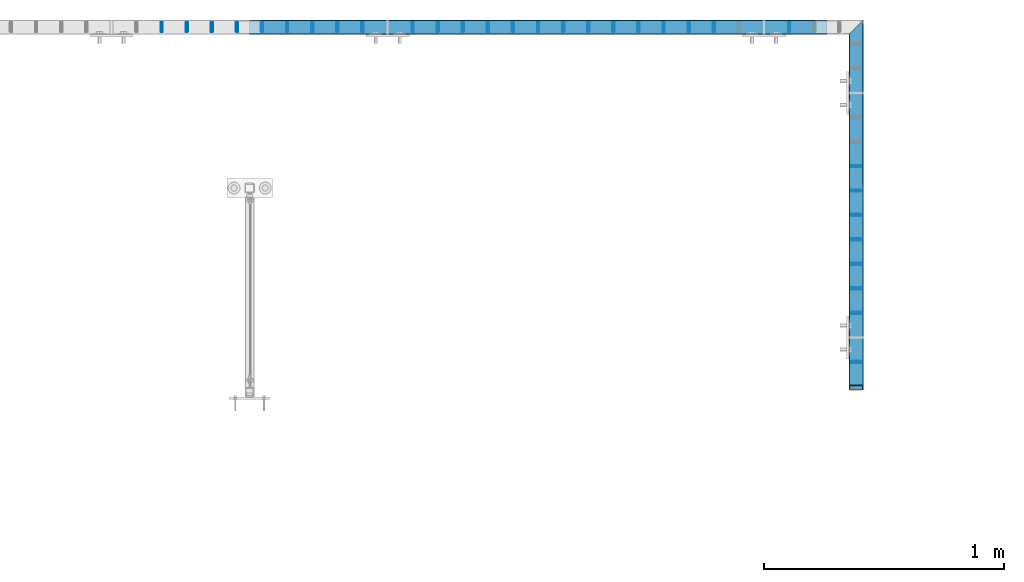
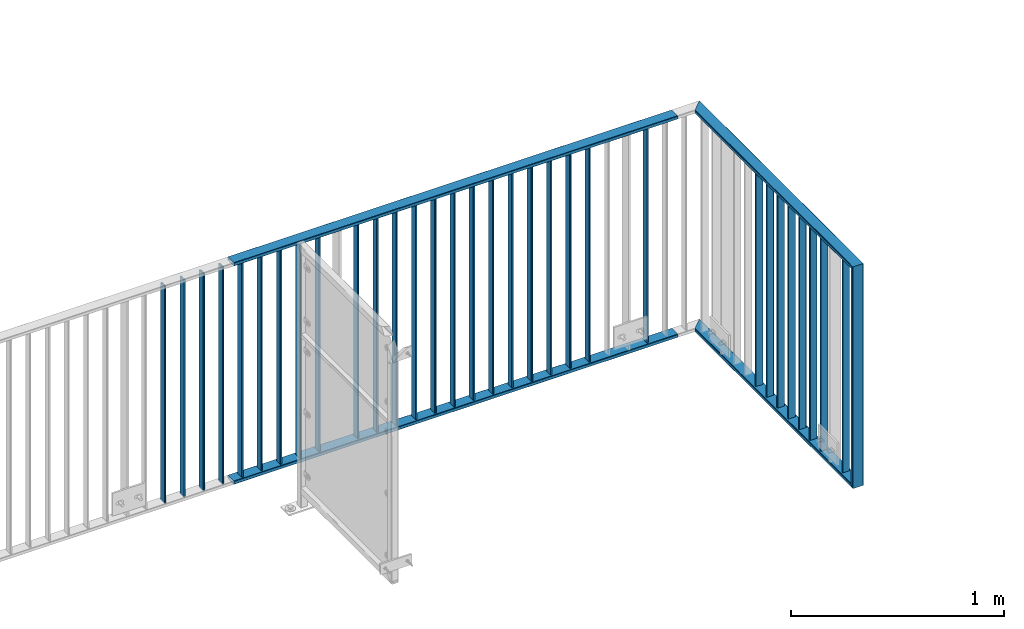
# One storey, part 12 of 156: 36 beams, 3 elements without a shape of their own.
"""IFC2X3 building model written with IfcOpenShell, lengths in millimetres."""

from ifc_helpers import new_model, si_unit, frame, origin_with_axes, origin_2d_with_axis, place, context, subcontext, project, spatial, hollow_rectangle, extrude, clip, halfspace, material, type_object, element, aggregate, save


model = new_model("IFC2X3")

# Units and contexts
model_context = context("Model", 3, precision=1e-05, world=origin_with_axes())
body_context = subcontext(model_context, "Body", "Model", "MODEL_VIEW")
ifc_project = project(units=[si_unit("LENGTHUNIT", "METRE", prefix="MILLI"), si_unit("AREAUNIT", "SQUARE_METRE"), si_unit("VOLUMEUNIT", "CUBIC_METRE"), si_unit("MASSUNIT", "GRAM", prefix="KILO"), si_unit("TIMEUNIT", "SECOND"), si_unit("PLANEANGLEUNIT", "RADIAN"), si_unit("SOLIDANGLEUNIT", "STERADIAN"), si_unit("THERMODYNAMICTEMPERATUREUNIT", "DEGREE_CELSIUS"), si_unit("LUMINOUSINTENSITYUNIT", "LUMEN")], contexts=[model_context])

# Site, building, storey
site_placement = place(None, origin_with_axes())
site = spatial("IfcSite", under=ifc_project, at=site_placement, CompositionType="ELEMENT")
building_placement = place(site_placement, origin_with_axes())
building = spatial("IfcBuilding", under=site, at=building_placement, Name="Undefined", CompositionType="ELEMENT")
storey_placement = place(building_placement, origin_with_axes())
storey = spatial("IfcBuildingStorey", under=building, at=storey_placement, Name="Undefined", CompositionType="ELEMENT", Elevation=0.0)

# Assembly, beams
assembly_1_placement = place(storey_placement, origin_with_axes())
assembly_1 = element("IfcElementAssembly", 1, at=assembly_1_placement, inside=storey, AssemblyPlace="NOTDEFINED", PredefinedType="RIGID_FRAME")
ifc_material = material(Name="STEEL/S235JR")
beam_type_1 = type_object("IfcBeamType", Name="K60/20/2", PredefinedType="NOTDEFINED")
beam_1_placement = place(assembly_1_placement, frame((17324.9994812012, 22558.0012658527, 4000.0), z_axis=(-1.0, 0.0, 0.0), x_axis=(0.0, 0.0, -1.0)))
beam_1 = element("IfcBeam", 2, at=beam_1_placement, type_object=beam_type_1, material=ifc_material, ObjectType="K60/20/2", context=body_context, shape_type="Clipping", body=[
    clip(clip(extrude(hollow_rectangle(XDim=20.0, YDim=60.0, WallThickness=2.0, InnerFilletRadius=2.0, OuterFilletRadius=4.0, at=origin_2d_with_axis()), frame((1280.2, 0.0, 0.0), z_axis=(-1.0, 0.0, 0.0), x_axis=(0.0, -1.0, 0.0)), (0.0, 0.0, 1.0), 1290.4), halfspace(frame((1270.0, 10.0, 0.0), z_axis=(0.707106781186548, -0.707106781186548, 0.0), x_axis=(0.0, 0.0, -1.0)), False)), halfspace(frame((20.0, -10.0, 0.0), z_axis=(-0.707106781186548, -0.707106781186548, 0.0), x_axis=(0.0, 0.0, -1.0)), False)),
])
beam_2_placement = place(assembly_1_placement, frame((17325.0016479492, 24031.4403835157, 2740.0), z_axis=(-1.0, 0.0, 0.0), x_axis=(0.0, -1.0, 0.0)))
beam_2 = element("IfcBeam", 3, at=beam_2_placement, type_object=beam_type_1, material=ifc_material, ObjectType="K60/20/2", context=body_context, shape_type="Clipping", body=[
    clip(clip(extrude(hollow_rectangle(XDim=20.0, YDim=60.0, WallThickness=2.0, InnerFilletRadius=2.0, OuterFilletRadius=4.0, at=origin_2d_with_axis()), frame((1513.83911766303, 0.0, 0.0), z_axis=(-1.0, 0.0, 0.0), x_axis=(0.0, -1.0, 0.0)), (0.0, 0.0, 1.0), 1580.79), halfspace(frame((1483.43911766303, -10.0, 0.002166748046875), z_axis=(-0.707106781186548, -0.707106781186548, 0.0), x_axis=(0.0, 0.0, -1.0)), True)), halfspace(frame((-56.5512297426903, 0.0, -30.0), z_axis=(-0.707106781186548, 0.0, 0.707106781186548), x_axis=(0.0, 1.0, 0.0)), False)),
])
beam_3_placement = place(assembly_1_placement, frame((17325.0016479492, 24031.4403835157, 3990.0), z_axis=(-1.0, 0.0, 0.0), x_axis=(0.0, -1.0, 0.0)))
beam_3 = element("IfcBeam", 4, at=beam_3_placement, type_object=beam_type_1, material=ifc_material, ObjectType="K60/20/2", context=body_context, shape_type="Clipping", body=[
    clip(clip(extrude(hollow_rectangle(XDim=20.0, YDim=60.0, WallThickness=2.0, InnerFilletRadius=2.0, OuterFilletRadius=4.0, at=origin_2d_with_axis()), frame((1513.83911766303, 0.0, 0.0), z_axis=(-1.0, 0.0, 0.0), x_axis=(0.0, -1.0, 0.0)), (0.0, 0.0, 1.0), 1580.79), halfspace(frame((1463.43911766303, -10.0, 0.002166748046875), z_axis=(-0.707106781186548, 0.707106781186548, 0.0), x_axis=(0.0, 0.0, -1.0)), True)), halfspace(frame((3.44877025730966, 0.0, 30.0), z_axis=(0.707106781186548, 0.0, -0.707106781186548), x_axis=(0.0, 1.0, 0.0)), True)),
])

assembly_2_placement = place(storey_placement, origin_with_axes())
assembly_2 = element("IfcElementAssembly", 5, at=assembly_2_placement, inside=storey, AssemblyPlace="NOTDEFINED", PredefinedType="RIGID_FRAME")
beam_4_placement = place(assembly_2_placement, frame((17202.6741455078, 24057.9916132584, 2740.0), z_axis=(0.0, -1.0, 0.0), x_axis=(-1.0, 0.0, 0.0)))
beam_4 = element("IfcBeam", 6, at=beam_4_placement, type_object=beam_type_1, material=ifc_material, ObjectType="K60/20/2", context=body_context, shape_type="SweptSolid", body=[
    extrude(hollow_rectangle(XDim=20.0, YDim=60.0, WallThickness=2.0, InnerFilletRadius=2.0, OuterFilletRadius=4.0, at=origin_2d_with_axis()), frame((2402.72054931641, 0.0, 0.0), z_axis=(-1.0, 0.0, 0.0), x_axis=(0.0, -1.0, 0.0)), (0.0, 0.0, 1.0), 2402.72),
])
beam_5_placement = place(assembly_2_placement, frame((17202.6741455078, 24057.9916132584, 3990.0), z_axis=(0.0, -1.0, 0.0), x_axis=(-1.0, 0.0, 0.0)))
beam_5 = element("IfcBeam", 7, at=beam_5_placement, type_object=beam_type_1, material=ifc_material, ObjectType="K60/20/2", context=body_context, shape_type="SweptSolid", body=[
    extrude(hollow_rectangle(XDim=20.0, YDim=60.0, WallThickness=2.0, InnerFilletRadius=2.0, OuterFilletRadius=4.0, at=origin_2d_with_axis()), frame((2402.72054931641, 0.0, 0.0), z_axis=(-1.0, 0.0, 0.0), x_axis=(0.0, -1.0, 0.0)), (0.0, 0.0, 1.0), 2402.72),
])

# Beam
beam_type_2 = type_object("IfcBeamType", Name="K40/10/1.5", PredefinedType="NOTDEFINED")
beam_6_placement = place(assembly_1_placement, frame((17325.0016402503, 22664.8503835168, 3980.00000000003), z_axis=(-1.0, 0.0, 0.0), x_axis=(0.0, 0.0, -1.0)))
beam_6 = element("IfcBeam", 8, at=beam_6_placement, type_object=beam_type_2, material=ifc_material, ObjectType="K40/10/1.5", context=body_context, shape_type="Clipping", body=[
    clip(clip(extrude(hollow_rectangle(XDim=10.0, YDim=40.0, WallThickness=1.5, InnerFilletRadius=1.5, OuterFilletRadius=3.0, at=origin_2d_with_axis()), frame((1237.00000000003, 0.0, 0.0), z_axis=(-1.0, 0.0, 0.0), x_axis=(0.0, -1.0, 0.0)), (0.0, 0.0, 1.0), 1244.0), halfspace(frame((1237.00000000003, 4.08341515816937, 47.1651964219418), z_axis=(1.0, 0.0, 0.0), x_axis=(0.0, -0.763991285051099, -0.645226562043109)), False)), halfspace(frame((-6.99999999997453, -4.08341515816574, 47.1651964219527), z_axis=(-1.0, 0.0, 0.0), x_axis=(0.0, 0.763991285051099, -0.645226562043109)), False)),
])

beam_7_placement = place(assembly_1_placement, frame((17325.0016402503, 22868.4103835168, 3980.00000000003), z_axis=(-1.0, 0.0, 0.0), x_axis=(0.0, 0.0, -1.0)))
beam_7 = element("IfcBeam", 9, at=beam_7_placement, type_object=beam_type_2, material=ifc_material, ObjectType="K40/10/1.5", context=body_context, shape_type="Clipping", body=[
    clip(clip(extrude(hollow_rectangle(XDim=10.0, YDim=40.0, WallThickness=1.5, InnerFilletRadius=1.5, OuterFilletRadius=3.0, at=origin_2d_with_axis()), frame((1237.00000000003, 0.0, 0.0), z_axis=(-1.0, 0.0, 0.0), x_axis=(0.0, -1.0, 0.0)), (0.0, 0.0, 1.0), 1244.0), halfspace(frame((1237.00000000003, 4.08341515816937, 47.1651964219418), z_axis=(1.0, 0.0, 0.0), x_axis=(0.0, -0.763991285051099, -0.645226562043109)), False)), halfspace(frame((-6.99999999997453, -4.08341515816574, 47.1651964219527), z_axis=(-1.0, 0.0, 0.0), x_axis=(0.0, 0.763991285051099, -0.645226562043109)), False)),
])

beam_8_placement = place(assembly_1_placement, frame((17325.0016402503, 22970.1903835168, 3980.00000000003), z_axis=(-1.0, 0.0, 0.0), x_axis=(0.0, 0.0, -1.0)))
beam_8 = element("IfcBeam", 10, at=beam_8_placement, type_object=beam_type_2, material=ifc_material, ObjectType="K40/10/1.5", context=body_context, shape_type="Clipping", body=[
    clip(clip(extrude(hollow_rectangle(XDim=10.0, YDim=40.0, WallThickness=1.5, InnerFilletRadius=1.5, OuterFilletRadius=3.0, at=origin_2d_with_axis()), frame((1237.00000000003, 0.0, 0.0), z_axis=(-1.0, 0.0, 0.0), x_axis=(0.0, -1.0, 0.0)), (0.0, 0.0, 1.0), 1244.0), halfspace(frame((1237.00000000003, 4.08341515816937, 47.1651964219418), z_axis=(1.0, 0.0, 0.0), x_axis=(0.0, -0.763991285051099, -0.645226562043109)), False)), halfspace(frame((-6.99999999997453, -4.08341515816574, 47.1651964219527), z_axis=(-1.0, 0.0, 0.0), x_axis=(0.0, 0.763991285051099, -0.645226562043109)), False)),
])

beam_9_placement = place(assembly_1_placement, frame((17325.0016402503, 23071.9703835168, 3980.00000000003), z_axis=(-1.0, 0.0, 0.0), x_axis=(0.0, 0.0, -1.0)))
beam_9 = element("IfcBeam", 11, at=beam_9_placement, type_object=beam_type_2, material=ifc_material, ObjectType="K40/10/1.5", context=body_context, shape_type="Clipping", body=[
    clip(clip(extrude(hollow_rectangle(XDim=10.0, YDim=40.0, WallThickness=1.5, InnerFilletRadius=1.5, OuterFilletRadius=3.0, at=origin_2d_with_axis()), frame((1237.00000000003, 0.0, 0.0), z_axis=(-1.0, 0.0, 0.0), x_axis=(0.0, -1.0, 0.0)), (0.0, 0.0, 1.0), 1244.0), halfspace(frame((1237.00000000003, 4.08341515816937, 47.1651964219418), z_axis=(1.0, 0.0, 0.0), x_axis=(0.0, -0.763991285051099, -0.645226562043109)), False)), halfspace(frame((-6.99999999997453, -4.08341515816574, 47.1651964219527), z_axis=(-1.0, 0.0, 0.0), x_axis=(0.0, 0.763991285051099, -0.645226562043109)), False)),
])

beam_10_placement = place(assembly_1_placement, frame((17325.0016402503, 23173.7503835168, 3980.00000000003), z_axis=(-1.0, 0.0, 0.0), x_axis=(0.0, 0.0, -1.0)))
beam_10 = element("IfcBeam", 12, at=beam_10_placement, type_object=beam_type_2, material=ifc_material, ObjectType="K40/10/1.5", context=body_context, shape_type="Clipping", body=[
    clip(clip(extrude(hollow_rectangle(XDim=10.0, YDim=40.0, WallThickness=1.5, InnerFilletRadius=1.5, OuterFilletRadius=3.0, at=origin_2d_with_axis()), frame((1237.00000000003, 0.0, 0.0), z_axis=(-1.0, 0.0, 0.0), x_axis=(0.0, -1.0, 0.0)), (0.0, 0.0, 1.0), 1244.0), halfspace(frame((1237.00000000003, 4.08341515816937, 47.1651964219418), z_axis=(1.0, 0.0, 0.0), x_axis=(0.0, -0.763991285051099, -0.645226562043109)), False)), halfspace(frame((-6.99999999997453, -4.08341515816574, 47.1651964219527), z_axis=(-1.0, 0.0, 0.0), x_axis=(0.0, 0.763991285051099, -0.645226562043109)), False)),
])

beam_11_placement = place(assembly_1_placement, frame((17325.0016402503, 23275.5303835168, 3980.00000000003), z_axis=(-1.0, 0.0, 0.0), x_axis=(0.0, 0.0, -1.0)))
beam_11 = element("IfcBeam", 13, at=beam_11_placement, type_object=beam_type_2, material=ifc_material, ObjectType="K40/10/1.5", context=body_context, shape_type="Clipping", body=[
    clip(clip(extrude(hollow_rectangle(XDim=10.0, YDim=40.0, WallThickness=1.5, InnerFilletRadius=1.5, OuterFilletRadius=3.0, at=origin_2d_with_axis()), frame((1237.00000000003, 0.0, 0.0), z_axis=(-1.0, 0.0, 0.0), x_axis=(0.0, -1.0, 0.0)), (0.0, 0.0, 1.0), 1244.0), halfspace(frame((1237.00000000003, 4.08341515816937, 47.1651964219418), z_axis=(1.0, 0.0, 0.0), x_axis=(0.0, -0.763991285051099, -0.645226562043109)), False)), halfspace(frame((-6.99999999997453, -4.08341515816574, 47.1651964219527), z_axis=(-1.0, 0.0, 0.0), x_axis=(0.0, 0.763991285051099, -0.645226562043109)), False)),
])

beam_12_placement = place(assembly_1_placement, frame((17325.0016402503, 23377.3103835168, 3980.00000000003), z_axis=(-1.0, 0.0, 0.0), x_axis=(0.0, 0.0, -1.0)))
beam_12 = element("IfcBeam", 14, at=beam_12_placement, type_object=beam_type_2, material=ifc_material, ObjectType="K40/10/1.5", context=body_context, shape_type="Clipping", body=[
    clip(clip(extrude(hollow_rectangle(XDim=10.0, YDim=40.0, WallThickness=1.5, InnerFilletRadius=1.5, OuterFilletRadius=3.0, at=origin_2d_with_axis()), frame((1237.00000000003, 0.0, 0.0), z_axis=(-1.0, 0.0, 0.0), x_axis=(0.0, -1.0, 0.0)), (0.0, 0.0, 1.0), 1244.0), halfspace(frame((1237.00000000003, 4.08341515816937, 47.1651964219418), z_axis=(1.0, 0.0, 0.0), x_axis=(0.0, -0.763991285051099, -0.645226562043109)), False)), halfspace(frame((-6.99999999997453, -4.08341515816574, 47.1651964219527), z_axis=(-1.0, 0.0, 0.0), x_axis=(0.0, 0.763991285051099, -0.645226562043109)), False)),
])

beam_13_placement = place(assembly_1_placement, frame((17325.0016402503, 23479.0903835168, 3980.00000000003), z_axis=(-1.0, 0.0, 0.0), x_axis=(0.0, 0.0, -1.0)))
beam_13 = element("IfcBeam", 15, at=beam_13_placement, type_object=beam_type_2, material=ifc_material, ObjectType="K40/10/1.5", context=body_context, shape_type="Clipping", body=[
    clip(clip(extrude(hollow_rectangle(XDim=10.0, YDim=40.0, WallThickness=1.5, InnerFilletRadius=1.5, OuterFilletRadius=3.0, at=origin_2d_with_axis()), frame((1237.00000000003, 0.0, 0.0), z_axis=(-1.0, 0.0, 0.0), x_axis=(0.0, -1.0, 0.0)), (0.0, 0.0, 1.0), 1244.0), halfspace(frame((1237.00000000003, 4.08341515816937, 47.1651964219418), z_axis=(1.0, 0.0, 0.0), x_axis=(0.0, -0.763991285051099, -0.645226562043109)), False)), halfspace(frame((-6.99999999997453, -4.08341515816574, 47.1651964219527), z_axis=(-1.0, 0.0, 0.0), x_axis=(0.0, 0.763991285051099, -0.645226562043109)), False)),
])

aggregate(assembly_1, [beam_6, beam_7, beam_8, beam_9, beam_10, beam_11, beam_12, beam_13, beam_1, beam_2, beam_3])

beam_14_placement = place(assembly_2_placement, frame((15479.0085961914, 24057.9916132584, 3980.00000000003), z_axis=(0.0, -1.0, 0.0), x_axis=(0.0, 0.0, -1.0)))
beam_14 = element("IfcBeam", 16, at=beam_14_placement, type_object=beam_type_2, material=ifc_material, ObjectType="K40/10/1.5", context=body_context, shape_type="Clipping", body=[
    clip(clip(extrude(hollow_rectangle(XDim=10.0, YDim=40.0, WallThickness=1.5, InnerFilletRadius=1.5, OuterFilletRadius=3.0, at=origin_2d_with_axis()), frame((1237.00000000003, 0.0, 0.0), z_axis=(-1.0, 0.0, 0.0), x_axis=(0.0, -1.0, 0.0)), (0.0, 0.0, 1.0), 1244.0), halfspace(frame((1237.00000000003, 4.34248751949781, 47.3810900558092), z_axis=(1.0, 0.0, 0.0), x_axis=(0.0, -0.768354814194188, -0.640024124158313)), False)), halfspace(frame((-6.99999999997453, -4.34248751950508, 47.3810900558092), z_axis=(-1.0, 0.0, 0.0), x_axis=(0.0, 0.7683548141934, -0.640024124159258)), False)),
])

beam_15_placement = place(assembly_2_placement, frame((17046.0585961914, 24057.9916132584, 3980.00000000003), z_axis=(0.0, -1.0, 0.0), x_axis=(0.0, 0.0, -1.0)))
beam_15 = element("IfcBeam", 17, at=beam_15_placement, type_object=beam_type_2, material=ifc_material, ObjectType="K40/10/1.5", context=body_context, shape_type="Clipping", body=[
    clip(clip(extrude(hollow_rectangle(XDim=10.0, YDim=40.0, WallThickness=1.5, InnerFilletRadius=1.5, OuterFilletRadius=3.0, at=origin_2d_with_axis()), frame((1237.00000000003, 0.0, 0.0), z_axis=(-1.0, 0.0, 0.0), x_axis=(0.0, -1.0, 0.0)), (0.0, 0.0, 1.0), 1244.0), halfspace(frame((1237.00000000003, 4.34248751949781, 47.3810900558092), z_axis=(1.0, 0.0, 0.0), x_axis=(0.0, -0.768354814194188, -0.640024124158313)), False)), halfspace(frame((-6.99999999997453, -4.34248751950508, 47.3810900558092), z_axis=(-1.0, 0.0, 0.0), x_axis=(0.0, 0.7683548141934, -0.640024124159258)), False)),
])

# Assembly, beams
assembly_3_placement = place(storey_placement, origin_with_axes())
assembly_3 = element("IfcElementAssembly", 18, at=assembly_3_placement, inside=storey, AssemblyPlace="NOTDEFINED", PredefinedType="RIGID_FRAME")
beam_16_placement = place(assembly_3_placement, frame((14434.3085961914, 24057.9916132584, 3980.00000000003), z_axis=(0.0, -1.0, 0.0), x_axis=(0.0, 0.0, -1.0)))
beam_16 = element("IfcBeam", 19, at=beam_16_placement, type_object=beam_type_2, material=ifc_material, ObjectType="K40/10/1.5", context=body_context, shape_type="Clipping", body=[
    clip(clip(extrude(hollow_rectangle(XDim=10.0, YDim=40.0, WallThickness=1.5, InnerFilletRadius=1.5, OuterFilletRadius=3.0, at=origin_2d_with_axis()), frame((1237.00000000003, 0.0, 0.0), z_axis=(-1.0, 0.0, 0.0), x_axis=(0.0, -1.0, 0.0)), (0.0, 0.0, 1.0), 1244.0), halfspace(frame((1237.00000000003, 4.34248751949781, 47.3810900558092), z_axis=(1.0, 0.0, 0.0), x_axis=(0.0, -0.768354814194188, -0.640024124158313)), False)), halfspace(frame((-6.99999999997453, -4.34248751950508, 47.3810900558092), z_axis=(-1.0, 0.0, 0.0), x_axis=(0.0, 0.7683548141934, -0.640024124159258)), False)),
])
beam_17_placement = place(assembly_3_placement, frame((14538.7785961914, 24057.9916132584, 3980.00000000003), z_axis=(0.0, -1.0, 0.0), x_axis=(0.0, 0.0, -1.0)))
beam_17 = element("IfcBeam", 20, at=beam_17_placement, type_object=beam_type_2, material=ifc_material, ObjectType="K40/10/1.5", context=body_context, shape_type="Clipping", body=[
    clip(clip(extrude(hollow_rectangle(XDim=10.0, YDim=40.0, WallThickness=1.5, InnerFilletRadius=1.5, OuterFilletRadius=3.0, at=origin_2d_with_axis()), frame((1237.00000000003, 0.0, 0.0), z_axis=(-1.0, 0.0, 0.0), x_axis=(0.0, -1.0, 0.0)), (0.0, 0.0, 1.0), 1244.0), halfspace(frame((1237.00000000003, 4.34248751949781, 47.3810900558092), z_axis=(1.0, 0.0, 0.0), x_axis=(0.0, -0.768354814194188, -0.640024124158313)), False)), halfspace(frame((-6.99999999997453, -4.34248751950508, 47.3810900558092), z_axis=(-1.0, 0.0, 0.0), x_axis=(0.0, 0.7683548141934, -0.640024124159258)), False)),
])
beam_18_placement = place(assembly_3_placement, frame((14643.2485961914, 24057.9916132584, 3980.00000000003), z_axis=(0.0, -1.0, 0.0), x_axis=(0.0, 0.0, -1.0)))
beam_18 = element("IfcBeam", 21, at=beam_18_placement, type_object=beam_type_2, material=ifc_material, ObjectType="K40/10/1.5", context=body_context, shape_type="Clipping", body=[
    clip(clip(extrude(hollow_rectangle(XDim=10.0, YDim=40.0, WallThickness=1.5, InnerFilletRadius=1.5, OuterFilletRadius=3.0, at=origin_2d_with_axis()), frame((1237.00000000003, 0.0, 0.0), z_axis=(-1.0, 0.0, 0.0), x_axis=(0.0, -1.0, 0.0)), (0.0, 0.0, 1.0), 1244.0), halfspace(frame((1237.00000000003, 4.34248751949781, 47.3810900558092), z_axis=(1.0, 0.0, 0.0), x_axis=(0.0, -0.768354814194188, -0.640024124158313)), False)), halfspace(frame((-6.99999999997453, -4.34248751950508, 47.3810900558092), z_axis=(-1.0, 0.0, 0.0), x_axis=(0.0, 0.7683548141934, -0.640024124159258)), False)),
])
beam_19_placement = place(assembly_3_placement, frame((14747.7185961914, 24057.9916132584, 3980.00000000003), z_axis=(0.0, -1.0, 0.0), x_axis=(0.0, 0.0, -1.0)))
beam_19 = element("IfcBeam", 22, at=beam_19_placement, type_object=beam_type_2, material=ifc_material, ObjectType="K40/10/1.5", context=body_context, shape_type="Clipping", body=[
    clip(clip(extrude(hollow_rectangle(XDim=10.0, YDim=40.0, WallThickness=1.5, InnerFilletRadius=1.5, OuterFilletRadius=3.0, at=origin_2d_with_axis()), frame((1237.00000000003, 0.0, 0.0), z_axis=(-1.0, 0.0, 0.0), x_axis=(0.0, -1.0, 0.0)), (0.0, 0.0, 1.0), 1244.0), halfspace(frame((1237.00000000003, 4.34248751949781, 47.3810900558092), z_axis=(1.0, 0.0, 0.0), x_axis=(0.0, -0.768354814194188, -0.640024124158313)), False)), halfspace(frame((-6.99999999997453, -4.34248751950508, 47.3810900558092), z_axis=(-1.0, 0.0, 0.0), x_axis=(0.0, 0.7683548141934, -0.640024124159258)), False)),
])
aggregate(assembly_3, [beam_16, beam_17, beam_18, beam_19])

# Beam
beam_20_placement = place(assembly_2_placement, frame((14852.1885961914, 24057.9916132584, 3980.00000000003), z_axis=(0.0, -1.0, 0.0), x_axis=(0.0, 0.0, -1.0)))
beam_20 = element("IfcBeam", 23, at=beam_20_placement, type_object=beam_type_2, material=ifc_material, ObjectType="K40/10/1.5", context=body_context, shape_type="Clipping", body=[
    clip(clip(extrude(hollow_rectangle(XDim=10.0, YDim=40.0, WallThickness=1.5, InnerFilletRadius=1.5, OuterFilletRadius=3.0, at=origin_2d_with_axis()), frame((1237.00000000003, 0.0, 0.0), z_axis=(-1.0, 0.0, 0.0), x_axis=(0.0, -1.0, 0.0)), (0.0, 0.0, 1.0), 1244.0), halfspace(frame((1237.00000000003, 4.34248751949781, 47.3810900558092), z_axis=(1.0, 0.0, 0.0), x_axis=(0.0, -0.768354814194188, -0.640024124158313)), False)), halfspace(frame((-6.99999999997453, -4.34248751950508, 47.3810900558092), z_axis=(-1.0, 0.0, 0.0), x_axis=(0.0, 0.7683548141934, -0.640024124159258)), False)),
])

beam_21_placement = place(assembly_2_placement, frame((14956.6585961914, 24057.9916132584, 3980.00000000003), z_axis=(0.0, -1.0, 0.0), x_axis=(0.0, 0.0, -1.0)))
beam_21 = element("IfcBeam", 24, at=beam_21_placement, type_object=beam_type_2, material=ifc_material, ObjectType="K40/10/1.5", context=body_context, shape_type="Clipping", body=[
    clip(clip(extrude(hollow_rectangle(XDim=10.0, YDim=40.0, WallThickness=1.5, InnerFilletRadius=1.5, OuterFilletRadius=3.0, at=origin_2d_with_axis()), frame((1237.00000000003, 0.0, 0.0), z_axis=(-1.0, 0.0, 0.0), x_axis=(0.0, -1.0, 0.0)), (0.0, 0.0, 1.0), 1244.0), halfspace(frame((1237.00000000003, 4.34248751949781, 47.3810900558092), z_axis=(1.0, 0.0, 0.0), x_axis=(0.0, -0.768354814194188, -0.640024124158313)), False)), halfspace(frame((-6.99999999997453, -4.34248751950508, 47.3810900558092), z_axis=(-1.0, 0.0, 0.0), x_axis=(0.0, 0.7683548141934, -0.640024124159258)), False)),
])

beam_22_placement = place(assembly_2_placement, frame((15061.1285961914, 24057.9916132584, 3980.00000000003), z_axis=(0.0, -1.0, 0.0), x_axis=(0.0, 0.0, -1.0)))
beam_22 = element("IfcBeam", 25, at=beam_22_placement, type_object=beam_type_2, material=ifc_material, ObjectType="K40/10/1.5", context=body_context, shape_type="Clipping", body=[
    clip(clip(extrude(hollow_rectangle(XDim=10.0, YDim=40.0, WallThickness=1.5, InnerFilletRadius=1.5, OuterFilletRadius=3.0, at=origin_2d_with_axis()), frame((1237.00000000003, 0.0, 0.0), z_axis=(-1.0, 0.0, 0.0), x_axis=(0.0, -1.0, 0.0)), (0.0, 0.0, 1.0), 1244.0), halfspace(frame((1237.00000000003, 4.34248751949781, 47.3810900558092), z_axis=(1.0, 0.0, 0.0), x_axis=(0.0, -0.768354814194188, -0.640024124158313)), False)), halfspace(frame((-6.99999999997453, -4.34248751950508, 47.3810900558092), z_axis=(-1.0, 0.0, 0.0), x_axis=(0.0, 0.7683548141934, -0.640024124159258)), False)),
])

beam_23_placement = place(assembly_2_placement, frame((15165.5985961914, 24057.9916132584, 3980.00000000003), z_axis=(0.0, -1.0, 0.0), x_axis=(0.0, 0.0, -1.0)))
beam_23 = element("IfcBeam", 26, at=beam_23_placement, type_object=beam_type_2, material=ifc_material, ObjectType="K40/10/1.5", context=body_context, shape_type="Clipping", body=[
    clip(clip(extrude(hollow_rectangle(XDim=10.0, YDim=40.0, WallThickness=1.5, InnerFilletRadius=1.5, OuterFilletRadius=3.0, at=origin_2d_with_axis()), frame((1237.00000000003, 0.0, 0.0), z_axis=(-1.0, 0.0, 0.0), x_axis=(0.0, -1.0, 0.0)), (0.0, 0.0, 1.0), 1244.0), halfspace(frame((1237.00000000003, 4.34248751949781, 47.3810900558092), z_axis=(1.0, 0.0, 0.0), x_axis=(0.0, -0.768354814194188, -0.640024124158313)), False)), halfspace(frame((-6.99999999997453, -4.34248751950508, 47.3810900558092), z_axis=(-1.0, 0.0, 0.0), x_axis=(0.0, 0.7683548141934, -0.640024124159258)), False)),
])

beam_24_placement = place(assembly_2_placement, frame((15270.0685961914, 24057.9916132584, 3980.00000000003), z_axis=(0.0, -1.0, 0.0), x_axis=(0.0, 0.0, -1.0)))
beam_24 = element("IfcBeam", 27, at=beam_24_placement, type_object=beam_type_2, material=ifc_material, ObjectType="K40/10/1.5", context=body_context, shape_type="Clipping", body=[
    clip(clip(extrude(hollow_rectangle(XDim=10.0, YDim=40.0, WallThickness=1.5, InnerFilletRadius=1.5, OuterFilletRadius=3.0, at=origin_2d_with_axis()), frame((1237.00000000003, 0.0, 0.0), z_axis=(-1.0, 0.0, 0.0), x_axis=(0.0, -1.0, 0.0)), (0.0, 0.0, 1.0), 1244.0), halfspace(frame((1237.00000000003, 4.34248751949781, 47.3810900558092), z_axis=(1.0, 0.0, 0.0), x_axis=(0.0, -0.768354814194188, -0.640024124158313)), False)), halfspace(frame((-6.99999999997453, -4.34248751950508, 47.3810900558092), z_axis=(-1.0, 0.0, 0.0), x_axis=(0.0, 0.7683548141934, -0.640024124159258)), False)),
])

beam_25_placement = place(assembly_2_placement, frame((15583.4785961914, 24057.9916132584, 3980.00000000003), z_axis=(0.0, -1.0, 0.0), x_axis=(0.0, 0.0, -1.0)))
beam_25 = element("IfcBeam", 28, at=beam_25_placement, type_object=beam_type_2, material=ifc_material, ObjectType="K40/10/1.5", context=body_context, shape_type="Clipping", body=[
    clip(clip(extrude(hollow_rectangle(XDim=10.0, YDim=40.0, WallThickness=1.5, InnerFilletRadius=1.5, OuterFilletRadius=3.0, at=origin_2d_with_axis()), frame((1237.00000000003, 0.0, 0.0), z_axis=(-1.0, 0.0, 0.0), x_axis=(0.0, -1.0, 0.0)), (0.0, 0.0, 1.0), 1244.0), halfspace(frame((1237.00000000003, 4.34248751949781, 47.3810900558092), z_axis=(1.0, 0.0, 0.0), x_axis=(0.0, -0.768354814194188, -0.640024124158313)), False)), halfspace(frame((-6.99999999997453, -4.34248751950508, 47.3810900558092), z_axis=(-1.0, 0.0, 0.0), x_axis=(0.0, 0.7683548141934, -0.640024124159258)), False)),
])

beam_26_placement = place(assembly_2_placement, frame((15687.9485961914, 24057.9916132584, 3980.00000000003), z_axis=(0.0, -1.0, 0.0), x_axis=(0.0, 0.0, -1.0)))
beam_26 = element("IfcBeam", 29, at=beam_26_placement, type_object=beam_type_2, material=ifc_material, ObjectType="K40/10/1.5", context=body_context, shape_type="Clipping", body=[
    clip(clip(extrude(hollow_rectangle(XDim=10.0, YDim=40.0, WallThickness=1.5, InnerFilletRadius=1.5, OuterFilletRadius=3.0, at=origin_2d_with_axis()), frame((1237.00000000003, 0.0, 0.0), z_axis=(-1.0, 0.0, 0.0), x_axis=(0.0, -1.0, 0.0)), (0.0, 0.0, 1.0), 1244.0), halfspace(frame((1237.00000000003, 4.34248751949781, 47.3810900558092), z_axis=(1.0, 0.0, 0.0), x_axis=(0.0, -0.768354814194188, -0.640024124158313)), False)), halfspace(frame((-6.99999999997453, -4.34248751950508, 47.3810900558092), z_axis=(-1.0, 0.0, 0.0), x_axis=(0.0, 0.7683548141934, -0.640024124159258)), False)),
])

beam_27_placement = place(assembly_2_placement, frame((15792.4185961914, 24057.9916132584, 3980.00000000003), z_axis=(0.0, -1.0, 0.0), x_axis=(0.0, 0.0, -1.0)))
beam_27 = element("IfcBeam", 30, at=beam_27_placement, type_object=beam_type_2, material=ifc_material, ObjectType="K40/10/1.5", context=body_context, shape_type="Clipping", body=[
    clip(clip(extrude(hollow_rectangle(XDim=10.0, YDim=40.0, WallThickness=1.5, InnerFilletRadius=1.5, OuterFilletRadius=3.0, at=origin_2d_with_axis()), frame((1237.00000000003, 0.0, 0.0), z_axis=(-1.0, 0.0, 0.0), x_axis=(0.0, -1.0, 0.0)), (0.0, 0.0, 1.0), 1244.0), halfspace(frame((1237.00000000003, 4.34248751949781, 47.3810900558092), z_axis=(1.0, 0.0, 0.0), x_axis=(0.0, -0.768354814194188, -0.640024124158313)), False)), halfspace(frame((-6.99999999997453, -4.34248751950508, 47.3810900558092), z_axis=(-1.0, 0.0, 0.0), x_axis=(0.0, 0.7683548141934, -0.640024124159258)), False)),
])

beam_28_placement = place(assembly_2_placement, frame((15896.8885961914, 24057.9916132584, 3980.00000000003), z_axis=(0.0, -1.0, 0.0), x_axis=(0.0, 0.0, -1.0)))
beam_28 = element("IfcBeam", 31, at=beam_28_placement, type_object=beam_type_2, material=ifc_material, ObjectType="K40/10/1.5", context=body_context, shape_type="Clipping", body=[
    clip(clip(extrude(hollow_rectangle(XDim=10.0, YDim=40.0, WallThickness=1.5, InnerFilletRadius=1.5, OuterFilletRadius=3.0, at=origin_2d_with_axis()), frame((1237.00000000003, 0.0, 0.0), z_axis=(-1.0, 0.0, 0.0), x_axis=(0.0, -1.0, 0.0)), (0.0, 0.0, 1.0), 1244.0), halfspace(frame((1237.00000000003, 4.34248751949781, 47.3810900558092), z_axis=(1.0, 0.0, 0.0), x_axis=(0.0, -0.768354814194188, -0.640024124158313)), False)), halfspace(frame((-6.99999999997453, -4.34248751950508, 47.3810900558092), z_axis=(-1.0, 0.0, 0.0), x_axis=(0.0, 0.7683548141934, -0.640024124159258)), False)),
])

beam_29_placement = place(assembly_2_placement, frame((16001.3585961914, 24057.9916132584, 3980.00000000003), z_axis=(0.0, -1.0, 0.0), x_axis=(0.0, 0.0, -1.0)))
beam_29 = element("IfcBeam", 32, at=beam_29_placement, type_object=beam_type_2, material=ifc_material, ObjectType="K40/10/1.5", context=body_context, shape_type="Clipping", body=[
    clip(clip(extrude(hollow_rectangle(XDim=10.0, YDim=40.0, WallThickness=1.5, InnerFilletRadius=1.5, OuterFilletRadius=3.0, at=origin_2d_with_axis()), frame((1237.00000000003, 0.0, 0.0), z_axis=(-1.0, 0.0, 0.0), x_axis=(0.0, -1.0, 0.0)), (0.0, 0.0, 1.0), 1244.0), halfspace(frame((1237.00000000003, 4.34248751949781, 47.3810900558092), z_axis=(1.0, 0.0, 0.0), x_axis=(0.0, -0.768354814194188, -0.640024124158313)), False)), halfspace(frame((-6.99999999997453, -4.34248751950508, 47.3810900558092), z_axis=(-1.0, 0.0, 0.0), x_axis=(0.0, 0.7683548141934, -0.640024124159258)), False)),
])

beam_30_placement = place(assembly_2_placement, frame((16105.8285961914, 24057.9916132584, 3980.00000000003), z_axis=(0.0, -1.0, 0.0), x_axis=(0.0, 0.0, -1.0)))
beam_30 = element("IfcBeam", 33, at=beam_30_placement, type_object=beam_type_2, material=ifc_material, ObjectType="K40/10/1.5", context=body_context, shape_type="Clipping", body=[
    clip(clip(extrude(hollow_rectangle(XDim=10.0, YDim=40.0, WallThickness=1.5, InnerFilletRadius=1.5, OuterFilletRadius=3.0, at=origin_2d_with_axis()), frame((1237.00000000003, 0.0, 0.0), z_axis=(-1.0, 0.0, 0.0), x_axis=(0.0, -1.0, 0.0)), (0.0, 0.0, 1.0), 1244.0), halfspace(frame((1237.00000000003, 4.34248751949781, 47.3810900558092), z_axis=(1.0, 0.0, 0.0), x_axis=(0.0, -0.768354814194188, -0.640024124158313)), False)), halfspace(frame((-6.99999999997453, -4.34248751950508, 47.3810900558092), z_axis=(-1.0, 0.0, 0.0), x_axis=(0.0, 0.7683548141934, -0.640024124159258)), False)),
])

beam_31_placement = place(assembly_2_placement, frame((16210.2985961914, 24057.9916132584, 3980.00000000003), z_axis=(0.0, -1.0, 0.0), x_axis=(0.0, 0.0, -1.0)))
beam_31 = element("IfcBeam", 34, at=beam_31_placement, type_object=beam_type_2, material=ifc_material, ObjectType="K40/10/1.5", context=body_context, shape_type="Clipping", body=[
    clip(clip(extrude(hollow_rectangle(XDim=10.0, YDim=40.0, WallThickness=1.5, InnerFilletRadius=1.5, OuterFilletRadius=3.0, at=origin_2d_with_axis()), frame((1237.00000000003, 0.0, 0.0), z_axis=(-1.0, 0.0, 0.0), x_axis=(0.0, -1.0, 0.0)), (0.0, 0.0, 1.0), 1244.0), halfspace(frame((1237.00000000003, 4.34248751949781, 47.3810900558092), z_axis=(1.0, 0.0, 0.0), x_axis=(0.0, -0.768354814194188, -0.640024124158313)), False)), halfspace(frame((-6.99999999997453, -4.34248751950508, 47.3810900558092), z_axis=(-1.0, 0.0, 0.0), x_axis=(0.0, 0.7683548141934, -0.640024124159258)), False)),
])

beam_32_placement = place(assembly_2_placement, frame((16314.7685961914, 24057.9916132584, 3980.00000000003), z_axis=(0.0, -1.0, 0.0), x_axis=(0.0, 0.0, -1.0)))
beam_32 = element("IfcBeam", 35, at=beam_32_placement, type_object=beam_type_2, material=ifc_material, ObjectType="K40/10/1.5", context=body_context, shape_type="Clipping", body=[
    clip(clip(extrude(hollow_rectangle(XDim=10.0, YDim=40.0, WallThickness=1.5, InnerFilletRadius=1.5, OuterFilletRadius=3.0, at=origin_2d_with_axis()), frame((1237.00000000003, 0.0, 0.0), z_axis=(-1.0, 0.0, 0.0), x_axis=(0.0, -1.0, 0.0)), (0.0, 0.0, 1.0), 1244.0), halfspace(frame((1237.00000000003, 4.34248751949781, 47.3810900558092), z_axis=(1.0, 0.0, 0.0), x_axis=(0.0, -0.768354814194188, -0.640024124158313)), False)), halfspace(frame((-6.99999999997453, -4.34248751950508, 47.3810900558092), z_axis=(-1.0, 0.0, 0.0), x_axis=(0.0, 0.7683548141934, -0.640024124159258)), False)),
])

beam_33_placement = place(assembly_2_placement, frame((16419.2385961914, 24057.9916132584, 3980.00000000003), z_axis=(0.0, -1.0, 0.0), x_axis=(0.0, 0.0, -1.0)))
beam_33 = element("IfcBeam", 36, at=beam_33_placement, type_object=beam_type_2, material=ifc_material, ObjectType="K40/10/1.5", context=body_context, shape_type="Clipping", body=[
    clip(clip(extrude(hollow_rectangle(XDim=10.0, YDim=40.0, WallThickness=1.5, InnerFilletRadius=1.5, OuterFilletRadius=3.0, at=origin_2d_with_axis()), frame((1237.00000000003, 0.0, 0.0), z_axis=(-1.0, 0.0, 0.0), x_axis=(0.0, -1.0, 0.0)), (0.0, 0.0, 1.0), 1244.0), halfspace(frame((1237.00000000003, 4.34248751949781, 47.3810900558092), z_axis=(1.0, 0.0, 0.0), x_axis=(0.0, -0.768354814194188, -0.640024124158313)), False)), halfspace(frame((-6.99999999997453, -4.34248751950508, 47.3810900558092), z_axis=(-1.0, 0.0, 0.0), x_axis=(0.0, 0.7683548141934, -0.640024124159258)), False)),
])

beam_34_placement = place(assembly_2_placement, frame((16523.7085961914, 24057.9916132584, 3980.00000000003), z_axis=(0.0, -1.0, 0.0), x_axis=(0.0, 0.0, -1.0)))
beam_34 = element("IfcBeam", 37, at=beam_34_placement, type_object=beam_type_2, material=ifc_material, ObjectType="K40/10/1.5", context=body_context, shape_type="Clipping", body=[
    clip(clip(extrude(hollow_rectangle(XDim=10.0, YDim=40.0, WallThickness=1.5, InnerFilletRadius=1.5, OuterFilletRadius=3.0, at=origin_2d_with_axis()), frame((1237.00000000003, 0.0, 0.0), z_axis=(-1.0, 0.0, 0.0), x_axis=(0.0, -1.0, 0.0)), (0.0, 0.0, 1.0), 1244.0), halfspace(frame((1237.00000000003, 4.34248751949781, 47.3810900558092), z_axis=(1.0, 0.0, 0.0), x_axis=(0.0, -0.768354814194188, -0.640024124158313)), False)), halfspace(frame((-6.99999999997453, -4.34248751950508, 47.3810900558092), z_axis=(-1.0, 0.0, 0.0), x_axis=(0.0, 0.7683548141934, -0.640024124159258)), False)),
])

beam_35_placement = place(assembly_2_placement, frame((16628.1785961914, 24057.9916132584, 3980.00000000003), z_axis=(0.0, -1.0, 0.0), x_axis=(0.0, 0.0, -1.0)))
beam_35 = element("IfcBeam", 38, at=beam_35_placement, type_object=beam_type_2, material=ifc_material, ObjectType="K40/10/1.5", context=body_context, shape_type="Clipping", body=[
    clip(clip(extrude(hollow_rectangle(XDim=10.0, YDim=40.0, WallThickness=1.5, InnerFilletRadius=1.5, OuterFilletRadius=3.0, at=origin_2d_with_axis()), frame((1237.00000000003, 0.0, 0.0), z_axis=(-1.0, 0.0, 0.0), x_axis=(0.0, -1.0, 0.0)), (0.0, 0.0, 1.0), 1244.0), halfspace(frame((1237.00000000003, 4.34248751949781, 47.3810900558092), z_axis=(1.0, 0.0, 0.0), x_axis=(0.0, -0.768354814194188, -0.640024124158313)), False)), halfspace(frame((-6.99999999997453, -4.34248751950508, 47.3810900558092), z_axis=(-1.0, 0.0, 0.0), x_axis=(0.0, 0.7683548141934, -0.640024124159258)), False)),
])

beam_36_placement = place(assembly_2_placement, frame((16732.6485961914, 24057.9916132584, 3980.00000000003), z_axis=(0.0, -1.0, 0.0), x_axis=(0.0, 0.0, -1.0)))
beam_36 = element("IfcBeam", 39, at=beam_36_placement, type_object=beam_type_2, material=ifc_material, ObjectType="K40/10/1.5", context=body_context, shape_type="Clipping", body=[
    clip(clip(extrude(hollow_rectangle(XDim=10.0, YDim=40.0, WallThickness=1.5, InnerFilletRadius=1.5, OuterFilletRadius=3.0, at=origin_2d_with_axis()), frame((1237.00000000003, 0.0, 0.0), z_axis=(-1.0, 0.0, 0.0), x_axis=(0.0, -1.0, 0.0)), (0.0, 0.0, 1.0), 1244.0), halfspace(frame((1237.00000000003, 4.34248751949781, 47.3810900558092), z_axis=(1.0, 0.0, 0.0), x_axis=(0.0, -0.768354814194188, -0.640024124158313)), False)), halfspace(frame((-6.99999999997453, -4.34248751950508, 47.3810900558092), z_axis=(-1.0, 0.0, 0.0), x_axis=(0.0, 0.7683548141934, -0.640024124159258)), False)),
])

aggregate(assembly_2, [beam_4, beam_14, beam_15, beam_20, beam_21, beam_22, beam_23, beam_24, beam_25, beam_26, beam_27, beam_28, beam_29, beam_30, beam_31, beam_32, beam_33, beam_34, beam_35, beam_36, beam_5])

save(model, "model.ifc")
